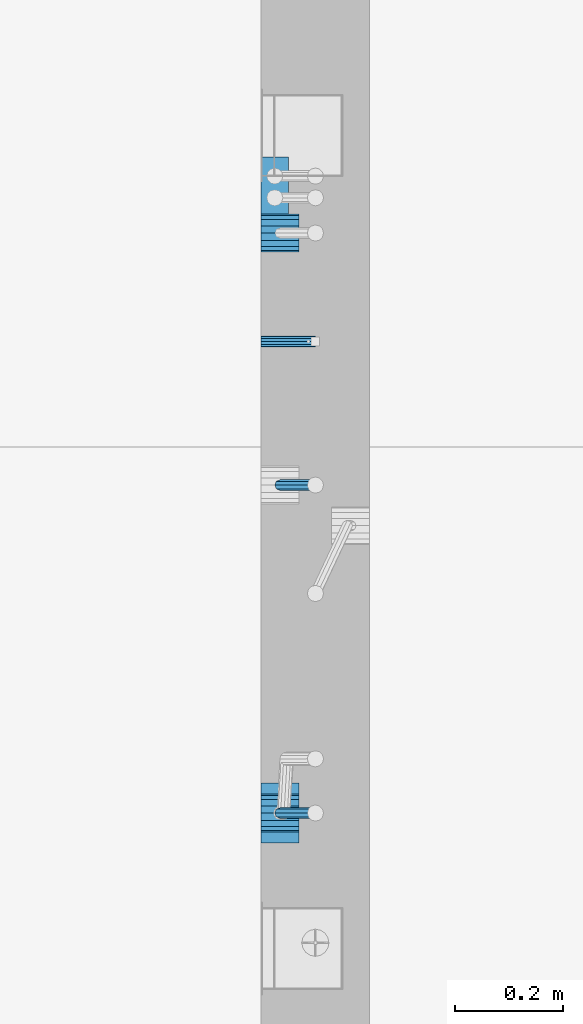
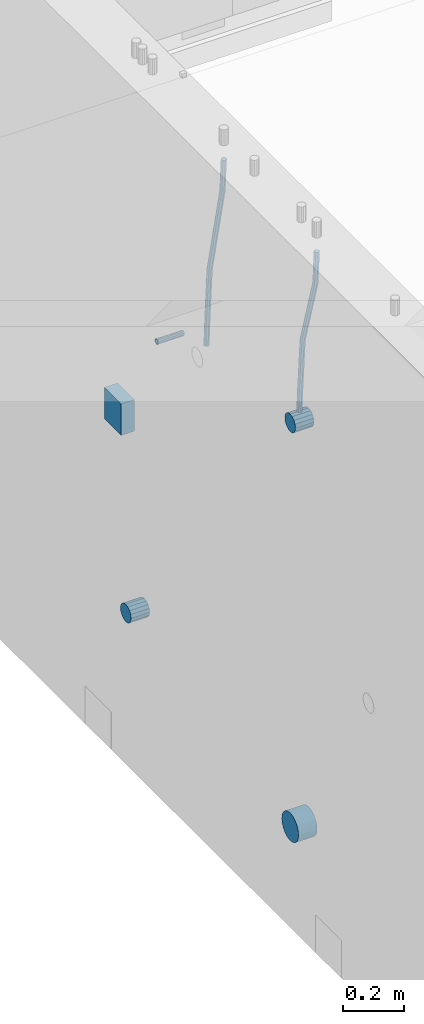
# One storey, part 144 of 352: 7 beams, 2 elements without a shape of their own.
"""IFC2X3 building model written with IfcOpenShell, lengths in millimetres."""

import ifcopenshell
import ifcopenshell.guid

model = None  # the IFC model being written
_history = None  # IfcOwnerHistory: only IFC2X3 demands one
_inside = {}  # id of a spatial element -> (the spatial element, [elements in it])
_under = {}  # id of a project, library or spatial element -> (it, [spatial elements below it])
_declared = {}  # id of a project -> (the project, [libraries it declares])
_typed = {}  # id of a type object -> (the type object, [elements of that type])
_made_of = {}  # id of a material, layer set ... -> (it, [elements and type objects made of it])


def new_model(schema):
    """Start an empty IFC model of exactly this schema.

    Asked for "IFC4X3", IfcOpenShell would pick the latest addendum, in which some entities
    have other attributes; the version numbers below select the first issue.
    IFC2X3 requires an IfcOwnerHistory on every rooted entity: one is made here for all.
    """
    global model, _history
    if schema == "IFC4X3":
        model = ifcopenshell.file(schema_version=(4, 3, 0, 0))
    else:
        model = ifcopenshell.file(schema=schema)
    _inside.clear()
    _under.clear()
    _declared.clear()
    _typed.clear()
    _made_of.clear()
    _history = None
    if model.schema == "IFC2X3":
        org = make("IfcOrganization", Name="unknown")
        user = make(
            "IfcPersonAndOrganization",
            ThePerson=make("IfcPerson", FamilyName="unknown"),
            TheOrganization=org,
        )
        app = make(
            "IfcApplication",
            ApplicationDeveloper=org,
            Version="unknown",
            ApplicationFullName="unknown",
            ApplicationIdentifier="unknown",
        )
        _history = make(
            "IfcOwnerHistory",
            OwningUser=user,
            OwningApplication=app,
            ChangeAction="ADDED",
            CreationDate=0,
        )
    return model


def make(cls, **values):
    """One entity of the class cls with the attributes given. An attribute that is None is left unset."""
    return model.create_entity(
        cls, **{name: value for name, value in values.items() if value is not None}
    )


def rooted(cls, **values):
    """An entity with a GlobalId (a new one), such as an element, a storey or a relation."""
    return make(cls, GlobalId=ifcopenshell.guid.new(), OwnerHistory=_history, **values)


def si_unit(unit_type, name, prefix=None):
    """IfcSIUnit, for example si_unit("LENGTHUNIT", "METRE", prefix="MILLI")."""
    return make("IfcSIUnit", UnitType=unit_type, Prefix=prefix, Name=name)


def assignment(units):
    """IfcUnitAssignment: the units of a project."""
    return None if units is None else make("IfcUnitAssignment", Units=units)


def point(xyz):
    """IfcCartesianPoint."""
    return None if xyz is None else make("IfcCartesianPoint", Coordinates=xyz)


def direction(xyz):
    """IfcDirection."""
    return None if xyz is None else make("IfcDirection", DirectionRatios=xyz)


def frame(location, z_axis=None, x_axis=None):
    """IfcAxis2Placement3D, a coordinate frame: its origin and axes. An axis left out is left unset."""
    return make(
        "IfcAxis2Placement3D",
        Location=point(location),
        Axis=direction(z_axis),
        RefDirection=direction(x_axis),
    )


def origin_with_axes():
    """The frame at (0, 0, 0) with the z axis (0, 0, 1) and the x axis (1, 0, 0) written out."""
    return frame((0.0, 0.0, 0.0), z_axis=(0.0, 0.0, 1.0), x_axis=(1.0, 0.0, 0.0))


def place(relative_to, where):
    """IfcLocalPlacement: puts the frame where relative to a parent placement (None: the world)."""
    return make(
        "IfcLocalPlacement", PlacementRelTo=relative_to, RelativePlacement=where
    )


def context(
    kind, dimensions, precision=None, world=None, true_north=None, identifier=None
):
    """IfcGeometricRepresentationContext, for example the 3D "Model" context."""
    return make(
        "IfcGeometricRepresentationContext",
        ContextIdentifier=identifier,
        ContextType=kind,
        CoordinateSpaceDimension=dimensions,
        Precision=precision,
        WorldCoordinateSystem=world,
        TrueNorth=true_north,
    )


def subcontext(parent, identifier, kind, view, scale=None):
    """IfcGeometricRepresentationSubContext, for example "Body" below "Model"."""
    return make(
        "IfcGeometricRepresentationSubContext",
        ContextIdentifier=identifier,
        ContextType=kind,
        ParentContext=parent,
        TargetScale=scale,
        TargetView=view,
    )


def project(units=None, contexts=None):
    """IfcProject with its units and contexts."""
    return rooted(
        "IfcProject",
        Name="project",
        RepresentationContexts=contexts,
        UnitsInContext=assignment(units),
    )


def spatial(cls, under=None, at=None, **own):
    """A site, building, storey or space (cls), placed at a placement, below another one or the project."""
    s = rooted(cls, ObjectPlacement=at, **own)
    if under is not None:
        _under.setdefault(under.id(), (under, []))[1].append(s)
    return s


def faces_of(points, faces, orient=None, outer=None):
    """IfcFace entities. A face is a list of loops; a loop is a list of indices into points, from 0.

    orient and outer hold one flag for each loop. By default every Orientation is true, the
    first loop of a face is its IfcFaceOuterBound and the others are IfcFaceBound.
    """
    made = []
    for i, loops in enumerate(faces):
        bounds = []
        for j, loop in enumerate(loops):
            is_outer = j == 0 if outer is None else outer[i][j]
            bounds.append(
                make(
                    "IfcFaceOuterBound" if is_outer else "IfcFaceBound",
                    Bound=make("IfcPolyLoop", Polygon=[points[k] for k in loop]),
                    Orientation=True if orient is None else orient[i][j],
                )
            )
        made.append(make("IfcFace", Bounds=bounds))
    return made


def faceted_brep(points, faces, orient=None, outer=None, voids=None):
    """IfcFacetedBrep: a solid bounded by flat faces; with voids (closed shells), ...WithVoids."""
    shared = [point(p) for p in points]
    hull = make("IfcClosedShell", CfsFaces=faces_of(shared, faces, orient, outer))
    if voids is None:
        return make("IfcFacetedBrep", Outer=hull)
    return make(
        "IfcFacetedBrepWithVoids",
        Outer=hull,
        Voids=[
            make(cls, CfsFaces=faces_of(shared, fs, o, b)) for cls, fs, o, b in voids
        ],
    )


def shape(context_of_items, identifier, shape_type, items):
    """IfcShapeRepresentation: the items that make up one representation, for example the "Body"."""
    return make(
        "IfcShapeRepresentation",
        ContextOfItems=context_of_items,
        RepresentationIdentifier=identifier,
        RepresentationType=shape_type,
        Items=items,
    )


def material(Name=None, Category=None):
    """IfcMaterial."""
    return make("IfcMaterial", Name=Name, Category=Category)


def made_of(thing, what):
    """Note that an element or type object is made of a material, layer set ...; save() writes the relation."""
    if what is not None:
        _made_of.setdefault(what.id(), (what, []))[1].append(thing)
    return thing


def type_object(cls, material=None, **own):
    """A type object (cls), such as IfcWallType, which elements share."""
    return made_of(rooted(cls, **own), material)


def element(
    cls,
    number,
    at=None,
    inside=None,
    cuts=None,
    type_object=None,
    material=None,
    context=None,
    identifier="Body",
    shape_type=None,
    held_by="IfcProductDefinitionShape",
    body=None,
    shapes=None,
    **own,
):
    """One element of the class cls, such as IfcWall. Its Tag is "e" and its number.

    at: its placement. inside: the storey or other place that contains it. cuts: it is an
    opening in that element (IfcRelVoidsElement). A single representation is given by context,
    identifier, shape_type and body (its items); several are given by shapes. held_by: the class
    of the entity that holds the representations. save() writes the other relations.
    """
    e = rooted(cls, Tag="e%d" % number, ObjectPlacement=at, **own)
    if body is not None:
        shapes = [shape(context, identifier, shape_type, body)]
    if shapes is not None:
        e.Representation = make(held_by, Representations=shapes)
    if inside is not None:
        _inside.setdefault(inside.id(), (inside, []))[1].append(e)
    if cuts is not None:
        rooted(
            "IfcRelVoidsElement", RelatingBuildingElement=cuts, RelatedOpeningElement=e
        )
    if type_object is not None:
        _typed.setdefault(type_object.id(), (type_object, []))[1].append(e)
    return made_of(e, material)


def aggregate(whole, parts):
    """IfcRelAggregates: a whole, such as a stair, and the parts it consists of."""
    return rooted("IfcRelAggregates", RelatingObject=whole, RelatedObjects=parts)


def save(model, path):
    """Write the relations noted so far, then the file.

    IfcRelAggregates (storeys below a building ...), IfcRelContainedInSpatialStructure (elements
    in a storey), IfcRelDefinesByType, IfcRelAssociatesMaterial and IfcRelDeclares: one each for
    every whole, place, type object, material and project.
    """
    for whole, parts in _under.values():
        aggregate(whole, parts)
    for where, things in _inside.values():
        rooted(
            "IfcRelContainedInSpatialStructure",
            RelatedElements=things,
            RelatingStructure=where,
        )
    for kind, things in _typed.values():
        rooted("IfcRelDefinesByType", RelatedObjects=things, RelatingType=kind)
    for what, things in _made_of.values():
        rooted("IfcRelAssociatesMaterial", RelatedObjects=things, RelatingMaterial=what)
    for by, libraries in _declared.values():
        rooted("IfcRelDeclares", RelatingContext=by, RelatedDefinitions=libraries)
    model.write(path)


model = new_model("IFC2X3")

# Units and contexts
model_context = context("Model", 3, precision=1e-05, world=origin_with_axes())
body_context = subcontext(model_context, "Body", "Model", "MODEL_VIEW")
ifc_project = project(units=[si_unit("LENGTHUNIT", "METRE", prefix="MILLI"), si_unit("AREAUNIT", "SQUARE_METRE"), si_unit("VOLUMEUNIT", "CUBIC_METRE"), si_unit("MASSUNIT", "GRAM", prefix="KILO"), si_unit("TIMEUNIT", "SECOND"), si_unit("PLANEANGLEUNIT", "RADIAN"), si_unit("SOLIDANGLEUNIT", "STERADIAN"), si_unit("THERMODYNAMICTEMPERATUREUNIT", "DEGREE_CELSIUS"), si_unit("LUMINOUSINTENSITYUNIT", "LUMEN")], contexts=[model_context])

# Site, building, storey
site_placement = place(None, origin_with_axes())
site = spatial("IfcSite", under=ifc_project, at=site_placement, CompositionType="ELEMENT")
building_placement = place(site_placement, origin_with_axes())
building = spatial("IfcBuilding", under=site, at=building_placement, CompositionType="ELEMENT")
storey_placement = place(building_placement, origin_with_axes())
storey = spatial("IfcBuildingStorey", under=building, at=storey_placement, Name="6", CompositionType="ELEMENT", Elevation=0.0)

# Assemblies, beams
assembly_1_placement = place(storey_placement, origin_with_axes())
assembly_1 = element("IfcElementAssembly", 1, at=assembly_1_placement, inside=storey, AssemblyPlace="NOTDEFINED", PredefinedType="REINFORCEMENT_UNIT")
assembly_2_placement = place(assembly_1_placement, origin_with_axes())
assembly_2 = element("IfcElementAssembly", 2, at=assembly_2_placement, Name="Steel Assembly", AssemblyPlace="NOTDEFINED", PredefinedType="RIGID_FRAME")
ifc_material_1 = material(Name="STEEL/Steel_Undefined")
beam_type_1 = type_object("IfcBeamType", PredefinedType="NOTDEFINED")
beam_1_placement = place(assembly_2_placement, frame((21710.0, 11374.9997839591, 98555.0), z_axis=(0.0, 1.0, 0.0), x_axis=(1.0, 0.0, 0.0)))
beam_1 = element("IfcBeam", 3, at=beam_1_placement, type_object=beam_type_1, material=ifc_material_1, Name="M16", context=body_context, shape_type="Brep", body=[
    faceted_brep([(0.0, -8.49999999999272, -1.45519152283669e-11), (0.0, -7.36121593215648, 4.24999999998545), (100.000000000262, -7.36121593215648, 4.24999999998545), (100.000000000262, -8.49999999999272, -1.45519152283669e-11), (0.0, -4.24999999998545, 7.36121593216376), (100.000000000262, -4.24999999998545, 7.36121593216376), (0.0, 1.45519152283669e-11, 8.49999999998545), (100.000000000262, 1.45519152283669e-11, 8.49999999998545), (0.0, 4.25000000001455, 7.36121593216376), (100.000000000262, 4.25000000001455, 7.36121593216376), (0.0, 7.36121593217104, 4.24999999998545), (100.000000000262, 7.36121593217104, 4.24999999998545), (0.0, 8.50000000000728, 0.0), (100.000000000262, 8.50000000000728, 0.0), (0.0, 7.36121593217104, -4.25000000001455), (100.000000000262, 7.36121593217104, -4.25000000001455), (0.0, 4.25000000000728, -7.36121593219286), (100.000000000262, 4.25000000000728, -7.36121593219286), (0.0, 7.27595761418343e-12, -8.5), (100.000000000262, 7.27595761418343e-12, -8.5), (0.0, -4.24999999999272, -7.36121593217831), (100.000000000262, -4.24999999999272, -7.36121593217831), (0.0, -7.36121593215648, -4.25), (100.000000000262, -7.36121593215648, -4.25), (0.0, -10.4999999999927, -1.45519152283669e-11), (0.0, -9.09326673972828, -5.25000000001455), (100.000000000262, -9.09326673972828, -5.25000000001455), (100.000000000262, -10.4999999999927, -1.45519152283669e-11), (0.0, -5.24999999998545, -9.09326673974283), (100.000000000262, -5.24999999998545, -9.09326673974283), (0.0, 7.27595761418343e-12, -10.5), (100.000000000262, 7.27595761418343e-12, -10.5), (0.0, 5.25000000001455, -9.09326673975738), (100.000000000262, 5.25000000001455, -9.09326673975738), (0.0, 9.09326673975011, -5.25000000001455), (100.000000000262, 9.09326673975011, -5.25000000001455), (0.0, 10.5000000000073, -1.45519152283669e-11), (100.000000000262, 10.5000000000073, -1.45519152283669e-11), (0.0, 9.09326673975011, 5.25), (100.000000000262, 9.09326673975011, 5.25), (0.0, 5.25000000000728, 9.09326673972828), (100.000000000262, 5.25000000000728, 9.09326673972828), (0.0, 1.45519152283669e-11, 10.4999999999854), (100.000000000262, 1.45519152283669e-11, 10.4999999999854), (0.0, -5.24999999999272, 9.09326673972828), (100.000000000262, -5.24999999999272, 9.09326673972828), (0.0, -9.09326673972828, 5.24999999998545), (100.000000000262, -9.09326673972828, 5.24999999998545)], [[[0, 1, 2, 3]], [[1, 4, 5, 2]], [[4, 6, 7, 5]], [[6, 8, 9, 7]], [[8, 10, 11, 9]], [[10, 12, 13, 11]], [[12, 14, 15, 13]], [[14, 16, 17, 15]], [[16, 18, 19, 17]], [[18, 20, 21, 19]], [[20, 22, 23, 21]], [[22, 0, 3, 23]], [[24, 25, 26, 27]], [[25, 28, 29, 26]], [[28, 30, 31, 29]], [[30, 32, 33, 31]], [[32, 34, 35, 33]], [[34, 36, 37, 35]], [[36, 38, 39, 37]], [[38, 40, 41, 39]], [[40, 42, 43, 41]], [[42, 44, 45, 43]], [[44, 46, 47, 45]], [[46, 24, 27, 47]], [[29, 31, 33, 35, 37, 39, 41, 43, 45, 47, 27, 26], [5, 7, 9, 11, 13, 15, 17, 19, 21, 23, 3, 2]], [[46, 44, 42, 40, 38, 36, 34, 32, 30, 28, 25, 24], [22, 20, 18, 16, 14, 12, 10, 8, 6, 4, 1, 0]]]),
])
aggregate(assembly_2, [beam_1])
ifc_material_2 = material()
beam_type_2 = type_object("IfcBeamType", Name="D20", PredefinedType="NOTDEFINED")
beam_2_placement = place(assembly_1_placement, frame((21744.9999977209, 10504.9999999961, 98795.0), z_axis=(0.999642804629538, 0.000205762999925497, -0.0267249099901003), x_axis=(0.0267249109941254, -4.30000210532798e-08, 0.999642825779465)))
beam_2 = element("IfcBeam", 4, at=beam_2_placement, type_object=beam_type_2, material=ifc_material_2, Name="JM20", ObjectType="D20", context=body_context, shape_type="Brep", body=[
    faceted_brep([(0.0, -10.0, 0.0), (-4.19531716033816e-08, -7.07106781186667, -7.07106781187031), (60.3902110151248, -7.07106779622882, -7.07106780570393), (60.3902110191848, -9.99999998436397, 6.15546014159918e-09), (0.0, 0.0, -10.0), (60.3902110119234, 1.56360329128802e-08, -9.99999999383726), (4.196772351861e-08, 7.07106781186303, -7.07106781186667), (60.3902110114723, 7.07106782750088, -7.07106780570757), (0.0, 10.0, 0.0), (60.3902110140189, 10.000000015636, 6.15909812040627e-09), (4.196772351861e-08, 7.07106781185939, 7.07106781185939), (60.3902110180788, 7.07106782750088, 7.07106781802213), (0.0, 0.0, 10.0), (60.3902110212803, 1.56378519022837e-08, 10.0000000061627), (-4.19531716033816e-08, -7.07106781187031, 7.07106781185939), (60.3902110217459, -7.07106779622882, 7.07106781802213), (61.0636251037213, -7.07106779605601, -7.07106780563481), (60.991799419251, -9.99999998403655, 6.21366780251265e-09), (61.0933608038758, 1.58179318532348e-08, -9.99999999376814), (61.0635953103047, 7.07106782767551, -7.07106780563481), (60.9917724058905, 10.0000000159635, 6.21366780251265e-09), (60.9199467214348, 7.07106782763913, 7.07106781808034), (60.8902110212803, 1.57651811605319e-08, 10.0000000062137), (60.919976514866, -7.07106779609421, 7.07106781808034), (61.736900248201, -7.07106495914195, -7.05738882369405), (61.5932788141945, -9.99999744984598, 0.0122201548947487), (61.7963655163912, 2.97800033877138e-06, -9.98571699394597), (61.7368406711612, 7.07107066446406, -7.05738942880998), (61.5931945595512, 10.0000025499758, 0.0122192991293559), (61.4495731255302, 7.07107005927173, 7.0818282777218), (61.3901078573399, 2.12213126360439e-06, 10.0101564479701), (61.4496327025554, -7.07106556433428, 7.08182888283409), (278.724613209561, -7.07015065944142, -2.64883307638229), (278.580991775569, -9.99908315014545, 4.42077590220288), (278.78407847778, 0.000917277700864361, -5.57716124663784), (278.724553632535, 7.07198496416277, -2.64883368149822), (278.580907520925, 10.0009168496781, 4.42077504644112), (278.437286086933, 7.07198435897226, 11.4903840250299), (278.377820818714, 0.000916421833608183, 14.4187121952782), (278.437345663944, -7.07015126463193, 11.4903846301422), (280.757740145142, -7.07014209265617, -2.60752588292962), (279.97914288567, -9.99907725889352, 4.4491822438722), (281.080112136013, 0.000926952270674519, -5.53051255744504), (280.757417718196, 7.07199352984026, -2.60753182838744), (279.978686905117, 10.0009227393621, 4.44917383572465), (279.200089645645, 7.0719875731229, 11.5058819625192), (278.877717654759, 0.000918528197871638, 14.4288686370419), (279.200412072576, -7.07014804937353, 11.5058879079807), (282.750959243713, -7.07005867588668, -2.20455064874841), (281.349849970706, -9.99901989442333, 4.72630231008952), (283.331077414448, 0.00102115578738449, -5.07542798552822), (282.750379126286, 7.07207693582313, -2.20460869228191), (281.349029560777, 10.0009800885819, 4.72622022413998), (279.947920287756, 7.07201887003976, 11.6570731829706), (279.367802117034, 0.000939038367505418, 14.5279505197614), (279.948500405197, -7.07011674167188, 11.6571312265078), (490.42756900216, -7.06136735270411, 39.782068138702), (489.026459729153, -9.99032857123893, 46.7129210975436), (491.007687172896, 0.00971247897177818, 36.9111908019222), (490.426988884734, 7.08076825901298, 39.7820100951685), (489.02563931921, 10.0096714117662, 46.7128390115868), (487.624530046218, 7.08071019322961, 53.6436919704247), (487.044411875468, 0.0096303615537181, 56.5145693072081), (487.625110163644, -7.06142541848567, 53.6437500139618), (491.139936791646, -7.06133753991526, 39.9260897251916), (490.366909417033, -9.99027247305094, 46.9839239327412), (491.497771635157, 0.00973298914141196, 37.0102726846344), (491.230799149358, 7.08080189869361, 39.9445188880345), (490.495408195638, 10.0097329219989, 47.0099867047757), (489.722380821026, 7.08079798886138, 54.0678209123216), (489.3645459775, 0.00972745980288892, 56.9836379528824), (489.631518463313, -7.06134144974749, 54.0493917494787), (491.866591294849, -7.07081326331172, 39.9357607788479), (491.734242157807, -10.008102771757, 47.0021217808862), (491.997684863585, 0.00321401835935831, 37.0169260358998), (492.050730029368, 7.07010983225518, 39.955431358132), (491.994653653514, 9.99018245447223, 47.0299401808879), (491.862304516457, 7.05289294603062, 54.0963011829335), (491.731210947721, -0.0211343356422731, 57.0151359258853), (491.678165781937, -7.08803014953628, 54.0766306036494), (512.839658019177, -7.34430634461387, 40.2148915801045), (512.707308882134, -10.2815958530537, 47.2812525821391), (512.970751587927, -0.270279062942791, 37.2960568371527), (513.023796753681, 6.79661675095485, 40.2345621593813), (512.967720377841, 9.7166893731719, 47.3090709821408), (512.835371240784, 6.77939986473211, 54.3754319841792), (512.704277672048, -0.294627416940784, 57.2942667271309), (512.651232506279, -7.36152323083843, 54.3557614048987), (513.475023168634, -7.35259163615956, 40.2233476626352), (513.367394028246, -10.2902034984181, 47.2900376634097), (513.548964110931, -0.277819072547572, 37.3037522746854), (513.54590325398, 6.78980837536619, 40.2415108811765), (513.467633606255, 9.71017040238803, 47.3157243334063), (513.360004465882, 6.77255854013129, 54.3824143341844), (513.28606352357, -0.302214023480701, 57.3020097221342), (513.289124380535, -7.36984147139265, 54.3642511156468), (514.110442121717, -7.35071708105352, 40.2316099536038), (514.027534909808, -10.2882349910469, 47.298629034136), (514.127225867254, -0.276123320652914, 37.311252921696), (514.068054455944, 6.79134521359629, 40.248263480742), (513.967589697961, 9.71166130597521, 47.3221806780894), (513.884682486052, 6.77414339598363, 54.3891997586288), (513.8678987405, -0.300450364420612, 57.309556790533), (513.927070151825, -7.36791889866981, 54.3725462314869), (614.131230002764, -7.05245493793518, 41.5289880054152), (614.048322790841, -9.98997284792858, 48.596007085951), (614.148013748316, 0.022138822467241, 38.608630973511), (614.088842336976, 7.08960735671644, 41.5456415325607), (613.988377579022, 10.0099234490935, 48.6195587299044), (613.905470367114, 7.07240553910196, 55.6865778104475), (613.888686621562, -0.00218822130045737, 58.6069348423516), (613.947858032887, -7.06965675554966, 55.6699242832983)], [[[0, 1, 2, 3]], [[1, 4, 5, 2]], [[4, 6, 7, 5]], [[6, 8, 9, 7]], [[8, 10, 11, 9]], [[10, 12, 13, 11]], [[12, 14, 15, 13]], [[14, 0, 3, 15]], [[14, 12, 10, 8, 6, 4, 1, 0]], [[3, 2, 16, 17]], [[2, 5, 18, 16]], [[5, 7, 19, 18]], [[7, 9, 20, 19]], [[9, 11, 21, 20]], [[11, 13, 22, 21]], [[13, 15, 23, 22]], [[15, 3, 17, 23]], [[17, 16, 24, 25]], [[16, 18, 26, 24]], [[18, 19, 27, 26]], [[19, 20, 28, 27]], [[20, 21, 29, 28]], [[21, 22, 30, 29]], [[22, 23, 31, 30]], [[23, 17, 25, 31]], [[25, 24, 32, 33]], [[24, 26, 34, 32]], [[26, 27, 35, 34]], [[27, 28, 36, 35]], [[28, 29, 37, 36]], [[29, 30, 38, 37]], [[30, 31, 39, 38]], [[31, 25, 33, 39]], [[33, 32, 40, 41]], [[32, 34, 42, 40]], [[34, 35, 43, 42]], [[35, 36, 44, 43]], [[36, 37, 45, 44]], [[37, 38, 46, 45]], [[38, 39, 47, 46]], [[39, 33, 41, 47]], [[41, 40, 48, 49]], [[40, 42, 50, 48]], [[42, 43, 51, 50]], [[43, 44, 52, 51]], [[44, 45, 53, 52]], [[45, 46, 54, 53]], [[46, 47, 55, 54]], [[47, 41, 49, 55]], [[49, 48, 56, 57]], [[48, 50, 58, 56]], [[50, 51, 59, 58]], [[51, 52, 60, 59]], [[52, 53, 61, 60]], [[53, 54, 62, 61]], [[54, 55, 63, 62]], [[55, 49, 57, 63]], [[57, 56, 64, 65]], [[56, 58, 66, 64]], [[58, 59, 67, 66]], [[59, 60, 68, 67]], [[60, 61, 69, 68]], [[61, 62, 70, 69]], [[62, 63, 71, 70]], [[63, 57, 65, 71]], [[65, 64, 72, 73]], [[64, 66, 74, 72]], [[66, 67, 75, 74]], [[67, 68, 76, 75]], [[68, 69, 77, 76]], [[69, 70, 78, 77]], [[70, 71, 79, 78]], [[71, 65, 73, 79]], [[73, 72, 80, 81]], [[72, 74, 82, 80]], [[74, 75, 83, 82]], [[75, 76, 84, 83]], [[76, 77, 85, 84]], [[77, 78, 86, 85]], [[78, 79, 87, 86]], [[79, 73, 81, 87]], [[81, 80, 88, 89]], [[80, 82, 90, 88]], [[82, 83, 91, 90]], [[83, 84, 92, 91]], [[84, 85, 93, 92]], [[85, 86, 94, 93]], [[86, 87, 95, 94]], [[87, 81, 89, 95]], [[89, 88, 96, 97]], [[88, 90, 98, 96]], [[90, 91, 99, 98]], [[91, 92, 100, 99]], [[92, 93, 101, 100]], [[93, 94, 102, 101]], [[94, 95, 103, 102]], [[95, 89, 97, 103]], [[97, 96, 104, 105]], [[96, 98, 106, 104]], [[98, 99, 107, 106]], [[99, 100, 108, 107]], [[100, 101, 109, 108]], [[101, 102, 110, 109]], [[102, 103, 111, 110]], [[103, 97, 105, 111]], [[106, 107, 108, 109, 110, 111, 105, 104]]]),
])
beam_3_placement = place(assembly_1_placement, frame((21744.9999977209, 11109.9999999961, 98690.0), z_axis=(0.999642804629538, 0.000205762999925497, -0.0267249099901003), x_axis=(0.0267249109941254, -4.30000210532798e-08, 0.999642825779465)))
beam_3 = element("IfcBeam", 5, at=beam_3_placement, type_object=beam_type_2, material=ifc_material_2, Name="JM20", ObjectType="D20", context=body_context, shape_type="Brep", body=[
    faceted_brep([(0.0, -10.0, 0.0), (-4.19531716033816e-08, -7.07106781186667, -7.07106781187031), (60.4266690400545, -7.0710677960451, -7.07106780570757), (60.4266690441291, -9.99999998418934, 6.15546014159918e-09), (0.0, 0.0, -10.0), (60.426669036824, 1.58106558956206e-08, -9.99999999384454), (4.196772351861e-08, 7.07106781186303, -7.07106781186667), (60.4266690363438, 7.07106782768096, -7.07106780570757), (0.0, 10.0, 0.0), (60.4266690388904, 10.0000000158179, 6.15182216279209e-09), (4.196772351861e-08, 7.07106781185939, 7.07106781185939), (60.4266690429649, 7.07106782768096, 7.07106781802577), (0.0, 0.0, 10.0), (60.4266690461809, 1.58179318532348e-08, 10.0000000061555), (-4.19531716033816e-08, -7.07106781187031, 7.07106781185939), (60.4266690466611, -7.07106779605238, 7.07106781802213), (61.0378400410118, -7.07106779588503, -7.07106780564936), (60.991799419251, -9.99999998403655, 6.21366780251265e-09), (61.0569027789461, 1.5985278878361e-08, -9.99999999378269), (61.0378209396877, 7.07106782784831, -7.07106780564936), (60.9917724058905, 10.0000000159635, 6.21366780251265e-09), (60.9457317841297, 7.07106782781193, 7.0710678180767), (60.9266690461809, 1.59488990902901e-08, 10.0000000062028), (60.9457508854539, -7.07106779591413, 7.0710678180767), (61.6489592143771, -7.07106614513759, -7.06310863441468), (61.5568818710308, -9.9999984576425, 0.00735959856683621), (61.6870830769039, 1.71821739058942e-06, -9.99179257185824), (61.6489210170112, 7.07106947854481, -7.06310888312146), (61.556827851804, 10.0000015422847, 0.00735924683976918), (61.4647505084577, 7.07106922979438, 7.07782747982128), (61.4266266459163, 1.36643211590126e-06, 10.0065114172685), (61.464788705809, -7.07106639389531, 7.07782772852806), (176.543135720174, -7.07075579406956, -5.56673531796696), (176.451058376813, -9.99968810657447, 1.50373291501455), (176.581259582701, 0.000312069292704109, -8.49541925541052), (176.543097522794, 7.07137982961285, -5.56673556667374), (176.451004357587, 10.00031189336, 1.50373256329476), (176.35892701424, 7.07137958085514, 8.57420079627263), (176.320803151699, 0.000311717507429421, 11.5028847337162), (176.358965211621, -7.07075604281999, 8.57420104497578), (177.098753836006, -7.07075429323595, -5.55949898843028), (176.98362511232, -9.99968666800123, 1.510669025065), (177.146421932586, 0.000313595905026887, -8.48805862247536), (177.098706077581, 7.07138133041735, -5.55949936166144), (176.983557571715, 10.0003133318824, 1.51066849724157), (176.868428848029, 7.07138095712435, 8.58083651073321), (176.820760751449, 0.000313067976094317, 11.5093961447819), (176.868476606425, -7.07075466652896, 8.58083688396073), (177.654312950661, -7.07075204110879, -5.54863964998367), (177.516135294456, -9.99968450931192, 1.52107783331303), (177.711524267797, 0.000315886711177882, -8.47701274570863), (177.654255632195, 7.07138358250813, -5.54864021007961), (177.516054233929, 10.0003154905207, 1.5210770412159), (177.377876577739, 7.0713830223176, 8.59079452451624), (177.320665260588, 0.000315094497636892, 11.5191676202448), (177.377933896176, -7.07075260129932, 8.59079508461218), (299.029771459231, -7.07026000924998, -3.17615191846562), (298.89159380304, -9.99919247745311, 3.89356556482744), (299.086982776382, 0.00080791857362783, -6.10452501419059), (299.029714140794, 7.07187561436331, -3.1761524785652), (298.891512742513, 10.0008075223832, 3.89356477273031), (298.753335086294, 7.07187505418005, 10.963282256027), (298.696123769172, 0.000807126352810883, 13.891655351752), (298.75339240476, -7.07026056943323, 10.963282816123), (300.5204182054, -7.07025396646532, -3.14701471758235), (299.971932015731, -9.99918809797782, 3.91468259446992), (300.747514543924, 0.000814650038591935, -6.07206712448169), (300.520191076153, 7.07188165646039, -3.14701859691559), (299.971610806504, 10.0008119008835, 3.91467710826691), (299.423124616849, 7.0718777693728, 10.9763744203192), (299.196028278326, 0.000809152865258511, 13.9014268272185), (299.423351746067, -7.0702578535529, 10.9763782996524), (301.997683885507, -7.07021227996847, -2.94561261413764), (301.042572372782, -9.99915788591352, 4.06064768581928), (302.393140241125, 0.000861087435623631, -5.84771176216236), (301.997288469822, 7.07192333820967, -2.94563943669345), (301.042013170576, 10.0008421062339, 4.0606097529926), (300.086901657865, 7.07189650029068, 11.0668700529459), (299.691445302247, 0.000823132886580424, 13.9689692009706), (300.087297073522, -7.07023911788747, 11.066896875509), (595.247547294217, -7.06193715364316, 37.0344262651415), (594.292435781506, -9.99088275958638, 44.0406865650948), (595.643003649835, 0.00913621376093943, 34.1323271171168), (595.247151878561, 7.08019846453499, 37.0343994425784), (594.291876579315, 10.0091172325574, 44.0406486322681), (593.336765066575, 7.08017162661235, 51.0469089322251), (592.941308710972, 0.00909825921189622, 53.9490080802498), (593.337160482261, -7.06196399156397, 51.0469357547881), (595.874536898147, -7.0619194608189, 37.1199065052715), (595.328959329563, -9.99085351025315, 44.1820003623798), (596.138420673757, 0.00915019377680437, 34.1998694908689), (595.966031119533, 7.08021875036138, 37.132407399582), (595.458351698282, 10.0091501489569, 44.1996792966529), (594.912774129698, 7.08021609952084, 51.2617731537612), (594.648890354089, 0.00914644492513617, 54.1818101681638), (594.821279908327, -7.06192211166126, 51.2492722594543), (596.507216806087, -7.07016973634745, 37.1283268498955), (596.374889946004, -10.0044926596274, 44.1959206657302), (596.638333902185, 0.00263122293472406, 34.2065228421343), (596.691434617649, 7.07075934023669, 37.1420618035991), (596.635413273558, 9.99380102503346, 44.2153448235404), (596.503086413475, 7.05947810175894, 51.2829386393751), (596.371969317406, -0.0133228575232351, 54.2047426471363), (596.318868601928, -7.08145097482702, 51.2692036856752), (617.802075790198, -7.34785905717763, 37.4117403882592), (617.669748930144, -10.282181980454, 44.4793342040939), (617.933192886281, -0.275058097895453, 34.4899363805016), (617.98629360176, 6.79307001940651, 37.4254753419664), (617.930272257669, 9.7161117042051, 44.498758361904), (617.797945397615, 6.78178878092876, 51.5663521777387), (617.666828301532, -0.291012178353412, 54.4881561855073), (617.613727586038, -7.35914029565538, 51.5526172240352), (618.437465979412, -7.3561446753265, 37.4201968040506), (618.329835563593, -10.2907896452944, 44.488119305166), (618.51143976918, -0.28259855563374, 34.4976322753282), (618.508424090105, 6.78626133094076, 37.4324243830088), (618.430185486082, 9.70959273336121, 44.5054117131695), (618.322555070263, 6.77494776339336, 51.5733342142812), (618.248581280495, -0.298598356299408, 54.4958987430036), (618.25159695957, -7.36745824287755, 51.5611066353231), (619.072909978044, -7.35426965608167, 37.428459048002), (618.989977939549, -10.2888211210229, 44.4967101569127), (619.089735886533, -0.2809021629364, 34.5051333804877), (619.030599275982, 6.78779861257681, 37.4391776831617), (618.930141570861, 9.7110836245156, 44.5118685961243), (618.847209532338, 6.77653215957434, 51.5801197050387), (618.830383623877, -0.296835333569106, 54.503445372553), (618.889520234414, -7.36553610908049, 51.569401069879), (719.093697115357, -7.05600751202655, 38.7258370901727), (719.010765076877, -9.9905589769678, 45.7940881990799), (719.110523023846, 0.017359981116897, 35.8025114226548), (719.051386413325, 7.08606075662829, 38.7365557253288), (718.950928708175, 10.0093457685707, 45.809246638295), (718.86799666968, 7.07479430362946, 52.8774977472058), (718.851170761191, 0.00142681048419036, 55.8008234147201), (718.910307371727, -7.06727396502902, 52.8667791120424)], [[[0, 1, 2, 3]], [[1, 4, 5, 2]], [[4, 6, 7, 5]], [[6, 8, 9, 7]], [[8, 10, 11, 9]], [[10, 12, 13, 11]], [[12, 14, 15, 13]], [[14, 0, 3, 15]], [[14, 12, 10, 8, 6, 4, 1, 0]], [[3, 2, 16, 17]], [[2, 5, 18, 16]], [[5, 7, 19, 18]], [[7, 9, 20, 19]], [[9, 11, 21, 20]], [[11, 13, 22, 21]], [[13, 15, 23, 22]], [[15, 3, 17, 23]], [[17, 16, 24, 25]], [[16, 18, 26, 24]], [[18, 19, 27, 26]], [[19, 20, 28, 27]], [[20, 21, 29, 28]], [[21, 22, 30, 29]], [[22, 23, 31, 30]], [[23, 17, 25, 31]], [[25, 24, 32, 33]], [[24, 26, 34, 32]], [[26, 27, 35, 34]], [[27, 28, 36, 35]], [[28, 29, 37, 36]], [[29, 30, 38, 37]], [[30, 31, 39, 38]], [[31, 25, 33, 39]], [[33, 32, 40, 41]], [[32, 34, 42, 40]], [[34, 35, 43, 42]], [[35, 36, 44, 43]], [[36, 37, 45, 44]], [[37, 38, 46, 45]], [[38, 39, 47, 46]], [[39, 33, 41, 47]], [[41, 40, 48, 49]], [[40, 42, 50, 48]], [[42, 43, 51, 50]], [[43, 44, 52, 51]], [[44, 45, 53, 52]], [[45, 46, 54, 53]], [[46, 47, 55, 54]], [[47, 41, 49, 55]], [[49, 48, 56, 57]], [[48, 50, 58, 56]], [[50, 51, 59, 58]], [[51, 52, 60, 59]], [[52, 53, 61, 60]], [[53, 54, 62, 61]], [[54, 55, 63, 62]], [[55, 49, 57, 63]], [[57, 56, 64, 65]], [[56, 58, 66, 64]], [[58, 59, 67, 66]], [[59, 60, 68, 67]], [[60, 61, 69, 68]], [[61, 62, 70, 69]], [[62, 63, 71, 70]], [[63, 57, 65, 71]], [[65, 64, 72, 73]], [[64, 66, 74, 72]], [[66, 67, 75, 74]], [[67, 68, 76, 75]], [[68, 69, 77, 76]], [[69, 70, 78, 77]], [[70, 71, 79, 78]], [[71, 65, 73, 79]], [[73, 72, 80, 81]], [[72, 74, 82, 80]], [[74, 75, 83, 82]], [[75, 76, 84, 83]], [[76, 77, 85, 84]], [[77, 78, 86, 85]], [[78, 79, 87, 86]], [[79, 73, 81, 87]], [[81, 80, 88, 89]], [[80, 82, 90, 88]], [[82, 83, 91, 90]], [[83, 84, 92, 91]], [[84, 85, 93, 92]], [[85, 86, 94, 93]], [[86, 87, 95, 94]], [[87, 81, 89, 95]], [[89, 88, 96, 97]], [[88, 90, 98, 96]], [[90, 91, 99, 98]], [[91, 92, 100, 99]], [[92, 93, 101, 100]], [[93, 94, 102, 101]], [[94, 95, 103, 102]], [[95, 89, 97, 103]], [[97, 96, 104, 105]], [[96, 98, 106, 104]], [[98, 99, 107, 106]], [[99, 100, 108, 107]], [[100, 101, 109, 108]], [[101, 102, 110, 109]], [[102, 103, 111, 110]], [[103, 97, 105, 111]], [[105, 104, 112, 113]], [[104, 106, 114, 112]], [[106, 107, 115, 114]], [[107, 108, 116, 115]], [[108, 109, 117, 116]], [[109, 110, 118, 117]], [[110, 111, 119, 118]], [[111, 105, 113, 119]], [[113, 112, 120, 121]], [[112, 114, 122, 120]], [[114, 115, 123, 122]], [[115, 116, 124, 123]], [[116, 117, 125, 124]], [[117, 118, 126, 125]], [[118, 119, 127, 126]], [[119, 113, 121, 127]], [[121, 120, 128, 129]], [[120, 122, 130, 128]], [[122, 123, 131, 130]], [[123, 124, 132, 131]], [[124, 125, 133, 132]], [[125, 126, 134, 133]], [[126, 127, 135, 134]], [[127, 121, 129, 135]], [[130, 131, 132, 133, 134, 135, 129, 128]]]),
])
beam_type_3 = type_object("IfcBeamType", Name="D70", PredefinedType="NOTDEFINED")
beam_4_placement = place(assembly_1_placement, frame((21709.9999977209, 10505.0, 98760.0), z_axis=(0.0, 0.0, 1.0), x_axis=(1.0, 0.0, 0.0)))
beam_4 = element("IfcBeam", 6, at=beam_4_placement, type_object=beam_type_3, material=ifc_material_2, ObjectType="D70", context=body_context, shape_type="Brep", body=[
    faceted_brep([(0.0, -35.0, 0.0), (0.0, -32.3357836378964, -13.3939201327739), (70.0, -32.3357836378964, -13.3939201327739), (70.0, -35.0, 0.0), (0.0, -24.7487373415279, -24.7487373415352), (70.0, -24.7487373415279, -24.7487373415352), (0.0, -13.3939201327776, -32.3357836379), (70.0, -13.3939201327776, -32.3357836379), (0.0, 0.0, -35.0), (70.0, 0.0, -35.0), (0.0, 13.3939201327776, -32.3357836379), (70.0, 13.3939201327776, -32.3357836379), (0.0, 24.7487373415279, -24.7487373415352), (70.0, 24.7487373415279, -24.7487373415352), (0.0, 32.3357836378964, -13.3939201327739), (70.0, 32.3357836378964, -13.3939201327739), (0.0, 35.0, 0.0), (70.0, 35.0, 0.0), (0.0, 32.3357836378964, 13.3939201327739), (70.0, 32.3357836378964, 13.3939201327739), (0.0, 24.7487373415279, 24.7487373415352), (70.0, 24.7487373415279, 24.7487373415352), (0.0, 13.3939201327776, 32.3357836379), (70.0, 13.3939201327776, 32.3357836379), (0.0, 0.0, 35.0), (70.0, 0.0, 35.0), (0.0, -13.3939201327776, 32.3357836379), (70.0, -13.3939201327776, 32.3357836379), (0.0, -24.7487373415279, 24.7487373415352), (70.0, -24.7487373415279, 24.7487373415352), (0.0, -32.3357836378964, 13.3939201327739), (70.0, -32.3357836378964, 13.3939201327739)], [[[0, 1, 2, 3]], [[1, 4, 5, 2]], [[4, 6, 7, 5]], [[6, 8, 9, 7]], [[8, 10, 11, 9]], [[10, 12, 13, 11]], [[12, 14, 15, 13]], [[14, 16, 17, 15]], [[16, 18, 19, 17]], [[18, 20, 21, 19]], [[20, 22, 23, 21]], [[22, 24, 25, 23]], [[24, 26, 27, 25]], [[26, 28, 29, 27]], [[28, 30, 31, 29]], [[30, 0, 3, 31]], [[5, 7, 9, 11, 13, 15, 17, 19, 21, 23, 25, 27, 29, 31, 3, 2]], [[30, 28, 26, 24, 22, 20, 18, 16, 14, 12, 10, 8, 6, 4, 1, 0]]]),
])
beam_5_placement = place(assembly_1_placement, frame((21709.9999977209, 11575.0, 97355.0), z_axis=(0.0, 0.0, 1.0), x_axis=(1.0, 0.0, 0.0)))
beam_5 = element("IfcBeam", 7, at=beam_5_placement, type_object=beam_type_3, material=ifc_material_2, ObjectType="D70", context=body_context, shape_type="Brep", body=[
    faceted_brep([(0.0, -35.0, 0.0), (0.0, -32.3357836378964, -13.3939201327739), (70.0, -32.3357836378964, -13.3939201327739), (70.0, -35.0, 0.0), (0.0, -24.7487373415279, -24.7487373415352), (70.0, -24.7487373415279, -24.7487373415352), (0.0, -13.3939201327776, -32.3357836379), (70.0, -13.3939201327776, -32.3357836379), (0.0, 0.0, -35.0), (70.0, 0.0, -35.0), (0.0, 13.3939201327776, -32.3357836379), (70.0, 13.3939201327776, -32.3357836379), (0.0, 24.7487373415279, -24.7487373415352), (70.0, 24.7487373415279, -24.7487373415352), (0.0, 32.3357836378964, -13.3939201327739), (70.0, 32.3357836378964, -13.3939201327739), (0.0, 35.0, 0.0), (70.0, 35.0, 0.0), (0.0, 32.3357836378964, 13.3939201327739), (70.0, 32.3357836378964, 13.3939201327739), (0.0, 24.7487373415279, 24.7487373415352), (70.0, 24.7487373415279, 24.7487373415352), (0.0, 13.3939201327776, 32.3357836379), (70.0, 13.3939201327776, 32.3357836379), (0.0, 0.0, 35.0), (70.0, 0.0, 35.0), (0.0, -13.3939201327776, 32.3357836379), (70.0, -13.3939201327776, 32.3357836379), (0.0, -24.7487373415279, 24.7487373415352), (70.0, -24.7487373415279, 24.7487373415352), (0.0, -32.3357836378964, 13.3939201327739), (70.0, -32.3357836378964, 13.3939201327739)], [[[0, 1, 2, 3]], [[1, 4, 5, 2]], [[4, 6, 7, 5]], [[6, 8, 9, 7]], [[8, 10, 11, 9]], [[10, 12, 13, 11]], [[12, 14, 15, 13]], [[14, 16, 17, 15]], [[16, 18, 19, 17]], [[18, 20, 21, 19]], [[20, 22, 23, 21]], [[22, 24, 25, 23]], [[24, 26, 27, 25]], [[26, 28, 29, 27]], [[28, 30, 31, 29]], [[30, 0, 3, 31]], [[5, 7, 9, 11, 13, 15, 17, 19, 21, 23, 25, 27, 29, 31, 3, 2]], [[30, 28, 26, 24, 22, 20, 18, 16, 14, 12, 10, 8, 6, 4, 1, 0]]]),
])
beam_type_4 = type_object("IfcBeamType", Name="D110", PredefinedType="NOTDEFINED")
beam_6_placement = place(assembly_1_placement, frame((21709.9999977209, 10505.0, 97155.0), z_axis=(0.0, 0.0, 1.0), x_axis=(1.0, 0.0, 0.0)))
beam_6 = element("IfcBeam", 8, at=beam_6_placement, type_object=beam_type_4, material=ifc_material_2, ObjectType="D110", context=body_context, shape_type="Brep", body=[
    faceted_brep([(0.0, -55.0, 0.0), (0.0, -52.3081083962352, -16.9959346906253), (70.0, -52.3081083962352, -16.9959346906253), (70.0, -55.0, 0.0), (0.0, -44.4959346906217, -32.328188876083), (70.0, -44.4959346906217, -32.328188876083), (0.0, -32.3281888760866, -44.4959346906253), (70.0, -32.3281888760866, -44.4959346906253), (0.0, -16.9959346906217, -52.3081083962315), (70.0, -16.9959346906217, -52.3081083962315), (0.0, 0.0, -55.0), (70.0, 0.0, -55.0), (0.0, 16.9959346906217, -52.3081083962315), (70.0, 16.9959346906217, -52.3081083962315), (0.0, 32.3281888760866, -44.4959346906253), (70.0, 32.3281888760866, -44.4959346906253), (0.0, 44.4959346906217, -32.328188876083), (70.0, 44.4959346906217, -32.328188876083), (0.0, 52.3081083962352, -16.9959346906253), (70.0, 52.3081083962352, -16.9959346906253), (0.0, 55.0, 0.0), (70.0, 55.0, 0.0), (0.0, 52.3081083962352, 16.9959346906253), (70.0, 52.3081083962352, 16.9959346906253), (0.0, 44.4959346906217, 32.328188876083), (70.0, 44.4959346906217, 32.328188876083), (0.0, 32.3281888760866, 44.4959346906253), (70.0, 32.3281888760866, 44.4959346906253), (0.0, 16.9959346906217, 52.3081083962315), (70.0, 16.9959346906217, 52.3081083962315), (0.0, 0.0, 55.0), (70.0, 0.0, 55.0), (0.0, -16.9959346906217, 52.3081083962315), (70.0, -16.9959346906217, 52.3081083962315), (0.0, -32.3281888760866, 44.4959346906253), (70.0, -32.3281888760866, 44.4959346906253), (0.0, -44.4959346906217, 32.328188876083), (70.0, -44.4959346906217, 32.328188876083), (0.0, -52.3081083962352, 16.9959346906253), (70.0, -52.3081083962352, 16.9959346906253)], [[[0, 1, 2, 3]], [[1, 4, 5, 2]], [[4, 6, 7, 5]], [[6, 8, 9, 7]], [[8, 10, 11, 9]], [[10, 12, 13, 11]], [[12, 14, 15, 13]], [[14, 16, 17, 15]], [[16, 18, 19, 17]], [[18, 20, 21, 19]], [[20, 22, 23, 21]], [[22, 24, 25, 23]], [[24, 26, 27, 25]], [[26, 28, 29, 27]], [[28, 30, 31, 29]], [[30, 32, 33, 31]], [[32, 34, 35, 33]], [[34, 36, 37, 35]], [[36, 38, 39, 37]], [[38, 0, 3, 39]], [[5, 7, 9, 11, 13, 15, 17, 19, 21, 23, 25, 27, 29, 31, 33, 35, 37, 39, 3, 2]], [[38, 36, 34, 32, 30, 28, 26, 24, 22, 20, 18, 16, 14, 12, 10, 8, 6, 4, 1, 0]]]),
])
beam_type_5 = type_object("IfcBeamType", Name="125X50", PredefinedType="NOTDEFINED")
beam_7_placement = place(assembly_1_placement, frame((21735.0, 11715.0, 98105.0), z_axis=(0.0, 0.0, 1.0), x_axis=(0.0, -1.0, 0.0)))
beam_7 = element("IfcBeam", 9, at=beam_7_placement, type_object=beam_type_5, material=ifc_material_2, Name="WM2", ObjectType="125X50", context=body_context, shape_type="Brep", body=[
    faceted_brep([(0.0, 25.0, -62.5), (0.0, 25.0, 62.5), (110.0, 25.0, 62.5), (110.0, 25.0, -62.5), (0.0, -25.0, 62.5), (110.0, -25.0, 62.5), (0.0, -25.0, -62.5), (110.0, -25.0, -62.5)], [[[0, 1, 2, 3]], [[1, 4, 5, 2]], [[4, 6, 7, 5]], [[6, 0, 3, 7]], [[5, 7, 3, 2]], [[0, 6, 4, 1]]]),
])
aggregate(assembly_1, [beam_2, beam_4, assembly_2, beam_7, beam_5, beam_3, beam_6])

save(model, "model.ifc")
